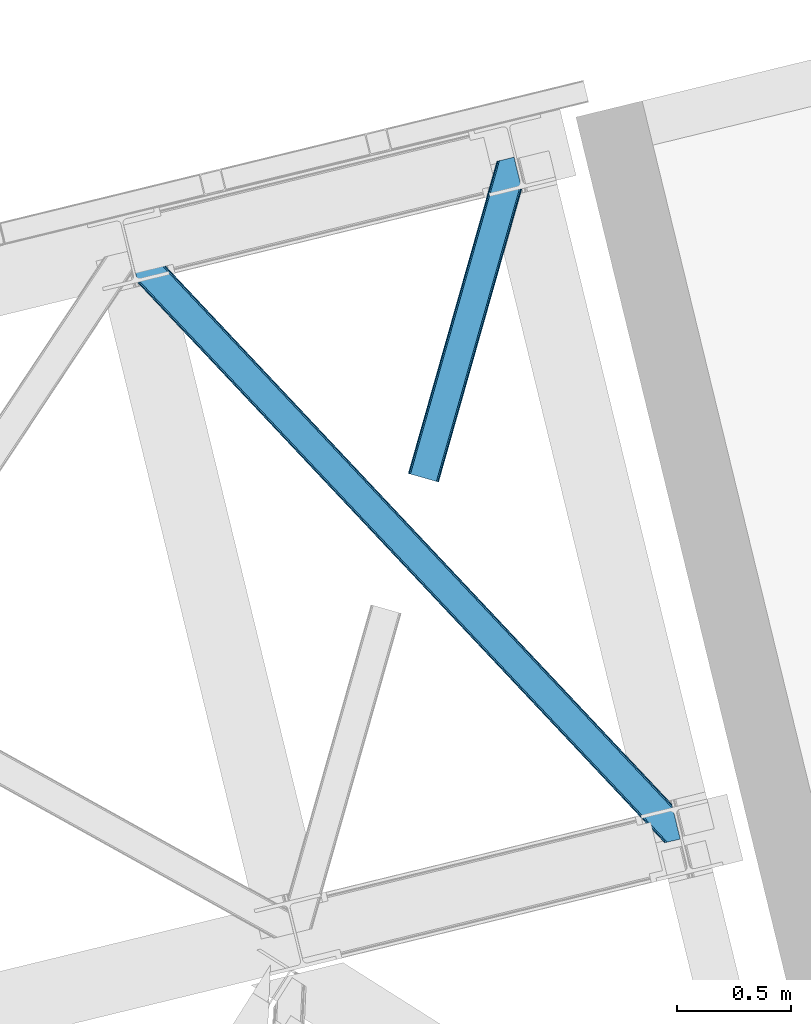
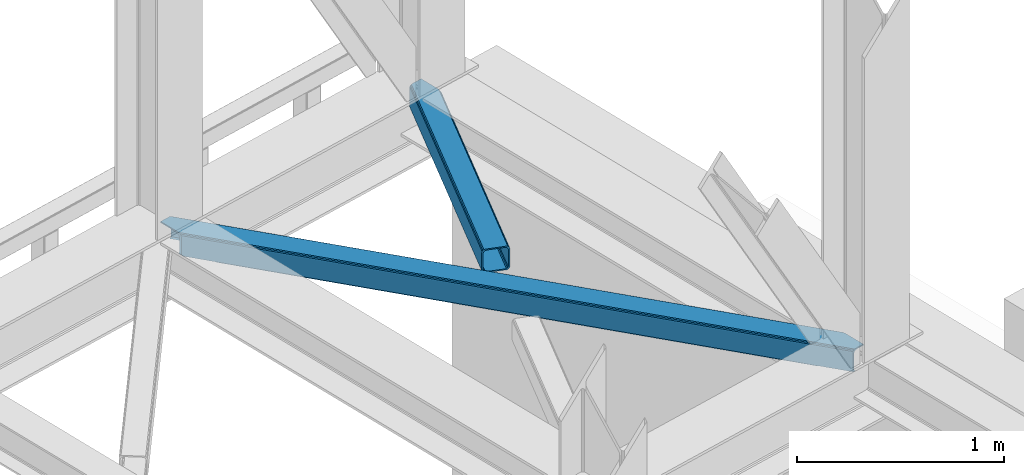
# One storey, part 85 of 92: 2 members.
"""IFC4 building model written with IfcOpenShell, lengths in millimetres."""

from ifc_helpers import new_model, entity, si_unit, converted_unit, derived_unit, direction, frame, origin, place, context, subcontext, project, spatial, triangles, type_object, element, save


model = new_model("IFC4")

# Units and contexts
model_context = context("Model", 3, precision=0.01, world=origin(), true_north=direction((6.12303176911189e-17, 1.0)))
plan_context = context("Plan", 3, precision=0.01, world=origin(), true_north=direction((6.12303176911189e-17, 1.0)))
body_context = subcontext(model_context, "Body", "Model", "MODEL_VIEW")
ifc_project = project(units=[si_unit("LENGTHUNIT", "METRE", prefix="MILLI"), si_unit("AREAUNIT", "SQUARE_METRE"), si_unit("VOLUMEUNIT", "CUBIC_METRE"), converted_unit("PLANEANGLEUNIT", "DEGREE", entity("IfcRatioMeasure", 0.0174532925199433), si_unit("PLANEANGLEUNIT", "RADIAN"), dimensions=[0, 0, 0, 0, 0, 0, 0]), si_unit("MASSUNIT", "GRAM", prefix="KILO"), derived_unit("MASSDENSITYUNIT", [(si_unit("MASSUNIT", "GRAM", prefix="KILO"), 1), (si_unit("LENGTHUNIT", "METRE"), -3)]), derived_unit("MOMENTOFINERTIAUNIT", [(si_unit("LENGTHUNIT", "METRE"), 4)]), si_unit("TIMEUNIT", "SECOND"), si_unit("FREQUENCYUNIT", "HERTZ"), si_unit("THERMODYNAMICTEMPERATUREUNIT", "DEGREE_CELSIUS"), derived_unit("THERMALTRANSMITTANCEUNIT", [(si_unit("MASSUNIT", "GRAM", prefix="KILO"), 1), (si_unit("THERMODYNAMICTEMPERATUREUNIT", "KELVIN"), -1), (si_unit("TIMEUNIT", "SECOND"), -3)]), derived_unit("VOLUMETRICFLOWRATEUNIT", [(si_unit("LENGTHUNIT", "METRE"), 3), (si_unit("TIMEUNIT", "SECOND"), -1)]), derived_unit("MASSFLOWRATEUNIT", [(si_unit("MASSUNIT", "GRAM", prefix="KILO"), 1), (si_unit("TIMEUNIT", "SECOND"), -1)]), derived_unit("ROTATIONALFREQUENCYUNIT", [(si_unit("TIMEUNIT", "SECOND"), -1)]), si_unit("ELECTRICCURRENTUNIT", "AMPERE"), si_unit("ELECTRICVOLTAGEUNIT", "VOLT"), si_unit("POWERUNIT", "WATT"), si_unit("FORCEUNIT", "NEWTON", prefix="KILO"), si_unit("ILLUMINANCEUNIT", "LUX"), si_unit("LUMINOUSFLUXUNIT", "LUMEN"), si_unit("LUMINOUSINTENSITYUNIT", "CANDELA"), derived_unit("USERDEFINED", [(si_unit("MASSUNIT", "GRAM", prefix="KILO"), -1), (si_unit("LENGTHUNIT", "METRE"), -2), (si_unit("TIMEUNIT", "SECOND"), 3), (si_unit("LUMINOUSFLUXUNIT", "LUMEN"), 1)]), derived_unit("LINEARVELOCITYUNIT", [(si_unit("LENGTHUNIT", "METRE"), 1), (si_unit("TIMEUNIT", "SECOND"), -1)]), si_unit("PRESSUREUNIT", "PASCAL"), derived_unit("USERDEFINED", [(si_unit("LENGTHUNIT", "METRE"), -2), (si_unit("MASSUNIT", "GRAM", prefix="KILO"), 1), (si_unit("TIMEUNIT", "SECOND"), -2)]), derived_unit("LINEARFORCEUNIT", [(si_unit("MASSUNIT", "GRAM", prefix="KILO"), 1), (si_unit("LENGTHUNIT", "METRE"), 1), (si_unit("TIMEUNIT", "SECOND"), -2), (si_unit("LENGTHUNIT", "METRE"), -1)]), derived_unit("PLANARFORCEUNIT", [(si_unit("MASSUNIT", "GRAM", prefix="KILO"), 1), (si_unit("LENGTHUNIT", "METRE"), 1), (si_unit("TIMEUNIT", "SECOND"), -2), (si_unit("LENGTHUNIT", "METRE"), -2)])], contexts=[model_context, plan_context])

# Site, building, storey
site_placement = place(None, origin())
site = spatial("IfcSite", under=ifc_project, at=site_placement, CompositionType="ELEMENT")
building_placement = place(site_placement, origin())
building = spatial("IfcBuilding", under=site, at=building_placement, CompositionType="ELEMENT")
storey_placement = place(building_placement, frame((0.0, 0.0, 15900.0)))
storey = spatial("IfcBuildingStorey", under=building, at=storey_placement, Name="05", CompositionType="ELEMENT", Elevation=15900.0)

# Members
member_type_1 = type_object("IfcMemberType", PredefinedType="BRACE")
member_1_placement = place(storey_placement, frame((-2893.85, 17476.17, 3510.02)))
element("IfcMember", 1, at=member_1_placement, inside=storey, type_object=member_type_1, ObjectType="Steel Horizontal Brace", PredefinedType="BRACE", context=body_context, shape_type="Tessellation", body=[
    triangles([(2390.20879182816, 136.983499145506, 140.000756835936), (2386.99318141937, 150.175717163085, 138.668280029298), (56.5227127075195, 2617.59836425781, 140.000756835936), (64.0010353088378, 2619.42150878906, 138.668280029298), (2384.26711235046, 161.358755493166, 134.87548828125), (70.3451248168944, 2620.96792602539, 134.87548828125), (2382.44560289383, 168.831555175781, 129.196765136719), (74.5788780212401, 2622.00042114258, 129.196765136719), (2381.80599803925, 171.455813598634, 122.499499511719), (76.0700660705566, 2622.36318969727, 122.499499511719), (2006.64328708649, 570.234960937501, 17.5000946044929), (2381.80599803925, 171.455813598634, 17.5000946044929), (1617.6124546051, 983.763208007811, 17.5000946044929), (1228.57718925476, 1397.2902923584, 17.5000946044929), (450.510873413086, 2224.3456237793, 17.5000946044929), (76.0700660705566, 2622.36318969727, 17.5000946044929), (839.546284103394, 1810.81853942871, 17.5000946044929), (26.1158477783201, 2496.68248901367, 140.000756835936), (0.0, 2603.82013549805, 140.000756835936), (2370.43223733902, 4.76366271972802, 140.000756835936), (2419.52200984955, 16.7303741455071, 140.000756835936), (2350.88942584991, 0.0, 122.499499511719), (2352.37603569031, 0.362768554688955, 129.196765136719), (34.5188232421874, 2462.2125, 122.499499511719), (33.8790367126462, 2464.83559570312, 129.196765136719), (2356.61443977356, 1.395263671875, 134.87548828125), (32.0576362609863, 2472.30723266601, 134.87548828125), (2362.95402374268, 2.94051818847583, 138.668280029298), (29.3316398620605, 2483.49259643555, 138.668280029298), (1193.06046180725, 1230.72371520996, 17.5000946044929), (1583.89125709534, 815.290933227538, 17.5000946044929), (1974.7174741745, 399.856988525389, 17.5000946044929), (2350.88942584991, 0.0, 17.5000946044929), (802.234317398071, 1646.15765991211, 17.5000946044929), (411.408027648926, 2061.59276733398, 17.5000946044929), (34.5188232421874, 2462.2125, 17.5000946044929), (2364.4315861702, 3.30096130371021, 127.875915527344), (2370.77113380432, 4.84621582031104, 131.668707275392), (2360.19314575195, 2.26730346679688, 122.197192382813), (2378.2538892746, 6.67052307129052, 133.00118408203), (2419.52200984955, 16.7303741455071, 133.00118408203), (2358.70653591156, 1.90569763183521, 115.499926757813), (2358.70653591156, 1.90569763183521, 24.5008300781265), (2360.19314575195, 2.26730346679688, 17.8035644531265), (2352.67877883911, 0.436019897460938, 10.8691040039048), (2353.04928674698, 0.526712036131357, 9.50058288574292), (2364.4315861702, 3.30096130371021, 12.1260040283196), (2368.18651685715, 4.21602172851635, 9.50058288574292), (1982.47063465118, 401.827798461913, 24.5008300781265), (1588.94283828735, 820.135986328125, 24.5008300781265), (1195.4104637146, 1238.44417419434, 24.5008300781265), (31.1576911926268, 2476.00003051758, 115.499926757813), (408.350074768066, 2075.05938720703, 24.5008300781265), (31.1576911926268, 2476.00003051758, 24.5008300781265), (801.882594680786, 1656.75236206055, 24.5008300781265), (25.9705078124998, 2497.28012695313, 131.668707275392), (22.7547157287595, 2510.4723449707, 133.00118408203), (28.6965042114257, 2486.09708862305, 127.875915527344), (30.517904663086, 2478.6231262207, 122.197192382813), (30.3873893737791, 2479.16030273437, 17.8710021972656), (34.5051612854004, 2462.26831054688, 16.5001556396492), (30.22809677124, 2479.8137512207, 16.5001556396492), (0.0, 2603.82013549805, 133.00118408203), (48.7057479858399, 2615.6938293457, 133.00118408203), (2393.56992387772, 123.194805908202, 133.00118408203), (2385.16713008881, 157.66712036133, 115.499926757813), (2385.80673494339, 155.042861938477, 122.197192382813), (66.7619132995605, 2620.09588623047, 122.197192382813), (68.2484504699705, 2620.4563293457, 115.499926757813), (2387.62824440002, 147.570062255858, 127.875915527344), (62.527869415283, 2619.06339111328, 127.875915527344), (2390.35431346893, 136.387023925781, 131.668707275392), (56.1837799072264, 2617.51697387695, 131.668707275392), (1226.23169288635, 1389.57215881348, 24.5008300781265), (1617.96868286133, 973.170831298827, 24.5008300781265), (2009.70560016632, 556.76950378418, 24.5008300781265), (2385.16713008881, 157.66712036133, 24.5008300781265), (834.490197372436, 1805.9723236084, 24.5008300781265), (442.753207397461, 2222.37365112305, 24.5008300781265), (68.2484504699705, 2620.4563293457, 24.5008300781265), (66.7619132995605, 2620.09588623047, 17.8035644531265), (74.2762802124021, 2621.92600708008, 10.8691040039048), (73.9056632995603, 2621.83764038086, 9.50058288574292), (62.527869415283, 2619.06339111328, 12.1260040283196), (58.7728660583493, 2618.14716796875, 9.50058288574292), (2385.9372502327, 154.508010864258, 17.8710021972656), (2386.09654283524, 153.854562377928, 16.5001556396492), (2381.81973266602, 171.398840332033, 16.5001556396492), (41.7939605712891, 2456.42215576172, 10.8039916992202), (36.8073463439941, 2482.3787109375, 9.50058288574292), (34.7757843017575, 2479.63701782226, 12.1260040283196), (43.3136352539063, 2455.68731689453, 9.50058288574292), (170.418958282471, 2340.35482177734, 9.50058288574292), (155.286451721192, 2336.66434936523, 9.50058288574292), (180.780244445801, 2508.2352722168, 9.50058288574292), (187.286533355713, 2481.54155273438, 9.50058288574292), (181.188068389893, 2507.60275268555, 9.25408630371021), (187.878357696533, 2480.72532348633, 9.42384338378906), (181.610426330567, 2506.94930419922, 9.00061340332104), (188.450415802002, 2479.24401855469, 9.11688537597729), (182.028424072265, 2506.29585571289, 8.74597778320458), (189.028287506103, 2477.75573730469, 8.80760192871094), (182.436248016357, 2505.66333618164, 8.50064392089917), (189.60005493164, 2476.27443237305, 8.50064392089917), (2381.54910964966, 154.028970336913, 12.1260040283196), (2374.53078804016, 177.24383239746, 10.8039916992202), (2379.51751127243, 151.288439941407, 9.50058288574292), (2373.01111335754, 177.979833984376, 9.50058288574292), (2233.21012630463, 306.80569152832, 9.50058288574292), (2248.34285087585, 310.495001220705, 9.50058288574292), (2005.67379684448, 569.32222595215, 10.8039916992202), (2002.91328220367, 566.723547363283, 5.12643127441333), (2244.78223972321, 309.626449584961, 5.12643127441333), (449.541455841064, 2223.43405151367, 10.8039916992202), (446.776508331299, 2220.83421020508, 5.12643127441333), (183.700996398926, 2500.47295532226, 5.12643127441333), (442.640714263916, 2216.94375, 1.33247680664135), (186.427283477783, 2489.28991699219, 1.33247680664135), (437.765721130371, 2212.35565795899, 0.0), (189.642784881592, 2476.09769897461, 0.0), (2238.43815021515, 308.080032348633, 1.33247680664135), (2230.95990028381, 306.256887817384, 0.0), (1998.77770614624, 562.833087158204, 1.33247680664135), (1993.89820747375, 558.24383239746, 0.0), (1616.64303703308, 982.850473022459, 10.8039916992202), (1227.60762634277, 1396.37755737305, 10.8039916992202), (838.572215652466, 1809.90464172363, 10.8039916992202), (1613.87794418335, 980.250631713869, 5.12643127441333), (1224.84253349304, 1393.77771606445, 5.12643127441333), (835.811773681641, 1807.30596313476, 5.12643127441333), (1609.74229545593, 976.36017150879, 1.33247680664135), (1220.71153564453, 1389.8884185791, 1.33247680664135), (831.676124954224, 1803.41666564941, 1.33247680664135), (1604.86730232239, 971.772079467773, 0.0), (1215.83203697205, 1385.29916381836, 0.0), (826.796626281738, 1798.82741088867, 0.0), (2008.73153171539, 555.855606079102, 17.8035644531265), (2005.9709444046, 553.256927490234, 12.1260040283196), (439.023202514648, 2218.86223754883, 12.1260040283196), (189.798298645019, 2475.46052856445, 8.41343994140698), (434.887699127197, 2214.97177734375, 8.3320495605476), (193.003916931152, 2462.31016845703, 7.00073547363354), (2001.83544101715, 549.366467285156, 8.3320495605476), (1996.95594234467, 544.777212524416, 7.00073547363354), (2223.14279022217, 304.352352905273, 7.00073547363354), (2230.46741580963, 306.137127685546, 8.81922912597656), (430.008055114746, 2210.38368530274, 7.00073547363354), (441.783789825439, 2221.45975341797, 17.8035644531265), (1610.09852371216, 965.767794799805, 8.3320495605476), (1605.21902503967, 961.178540039062, 7.00073547363354), (1213.4820350647, 1377.57986755371, 7.00073547363354), (1218.36153373718, 1382.16912231445, 8.3320495605476), (821.745045089722, 1793.98119506836, 7.00073547363354), (826.624543762207, 1798.5704498291, 8.3320495605476), (1614.23402709961, 969.658255004884, 12.1260040283196), (1222.49703712463, 1386.05958251953, 12.1260040283196), (830.760192489624, 1802.46091003418, 12.1260040283196), (1616.9946144104, 972.256933593751, 17.8035644531265), (1225.25762443542, 1388.6582611084, 17.8035644531265), (833.520634460449, 1805.05958862305, 17.8035644531265), (219.79792098999, 2352.39129638672, 0.0), (219.79792098999, 2352.39129638672, 7.00073547363354), (173.166464996338, 2341.02454833984, 8.81922912597656), (180.486367034912, 2342.80816040039, 7.00073547363354), (172.669402313232, 2340.90130004883, 0.0), (165.191079711914, 2339.08048095703, 1.33247680664135), (158.846990203857, 2337.5340637207, 5.12643127441333), (424.15317993164, 2073.5827331543, 0.0), (814.97932434082, 1658.14878845215, 0.0), (1205.81011962891, 1242.71600646973, 0.0), (1987.46262645721, 411.846954345703, 0.0), (1596.63640937805, 827.282061767579, 0.0), (2192.71020011902, 296.934201049804, 0.0), (2226.68196372986, 157.568289184572, 0.0), (421.095517730713, 2087.04935302735, 7.00073547363354), (814.627746963501, 1668.74349060059, 7.00073547363354), (1208.15561599731, 1250.43414001465, 7.00073547363354), (1995.22029247284, 413.820089721681, 7.00073547363354), (2192.71020011902, 296.934201049804, 7.00073547363354), (2223.3208316803, 171.356982421876, 7.00073547363354), (1601.68799057007, 832.127114868163, 7.00073547363354), (1975.68703708649, 400.768560791017, 10.8039916992202), (412.377445220947, 2062.50433959961, 10.8039916992202), (415.142683410645, 2065.1041809082, 5.12643127441333), (2235.13660755157, 126.065560913084, 9.25408630371021), (2234.7142496109, 126.717846679687, 9.00061340332104), (2235.54457683563, 125.433041381835, 9.50058288574292), (2234.29632453918, 127.372457885744, 8.74597778320458), (2233.88835525513, 128.004977416993, 8.50064392089917), (1978.45205726624, 403.368402099608, 5.12643127441333), (2232.62367954254, 133.193032836913, 5.12643127441333), (2229.89761047363, 144.376071166993, 1.33247680664135), (1982.58312778473, 407.257699584959, 1.33247680664135), (419.278186798096, 2068.99464111328, 1.33247680664135), (1591.75691070557, 822.692807006835, 1.33247680664135), (1200.93062095642, 1238.12675170898, 1.33247680664135), (810.104331207275, 1653.56069641113, 1.33247680664135), (1587.62126197815, 818.802346801756, 5.12643127441333), (1196.79511756897, 1234.2362915039, 5.12643127441333), (805.968827819824, 1649.67023620605, 5.12643127441333), (1584.86082000732, 816.203668212889, 10.8039916992202), (1194.03453025818, 1231.63761291504, 10.8039916992202), (803.203734970093, 1647.07039489746, 10.8039916992202), (1990.34079380035, 409.230834960938, 8.3320495605476), (2227.21637878418, 155.690496826173, 8.8831787109375), (2226.72454833984, 157.393881225587, 8.50064392089917), (1986.20521774292, 405.340374755859, 12.1260040283196), (2229.03814258575, 152.124435424805, 9.50058288574292), (2228.43301963806, 153.310409545898, 9.2947814941399), (2227.82150173187, 154.503359985352, 9.08898010254052), (2226.52637729645, 158.206622314454, 8.41343994140698), (416.220524597168, 2082.46126098633, 8.3320495605476), (412.084730529785, 2078.5731262207, 12.1260040283196), (409.319783020019, 2075.97328491211, 17.8035644531265), (1983.44470310211, 402.741696166991, 17.8035644531265), (1589.91240119934, 821.048721313477, 17.8035644531265), (1196.38002662659, 1239.35690917969, 17.8035644531265), (802.852157592773, 1657.6650970459, 17.8035644531265), (1592.67284317017, 823.647399902344, 12.1260040283196), (1199.14497413635, 1241.95675048828, 12.1260040283196), (805.612599563598, 1660.26377563476, 12.1260040283196), (1596.80849189758, 827.537860107423, 8.3320495605476), (1203.28062286377, 1245.84604797363, 8.3320495605476), (809.748248291015, 1664.15423583984, 8.3320495605476)], [[1, 2, 3], [4, 3, 2], [2, 5, 4], [6, 4, 5], [5, 7, 6], [8, 6, 7], [7, 9, 8], [10, 8, 9], [11, 9, 12], [9, 11, 13], [9, 14, 10], [14, 9, 13], [15, 16, 10], [17, 10, 14], [10, 17, 15], [3, 18, 1], [3, 19, 18], [20, 1, 18], [21, 1, 20], [22, 23, 24], [25, 24, 23], [23, 26, 25], [27, 25, 26], [26, 28, 27], [29, 27, 28], [28, 20, 29], [18, 29, 20], [30, 22, 24], [22, 31, 32], [30, 31, 22], [32, 33, 22], [34, 24, 35], [24, 34, 30], [36, 35, 24], [37, 38, 28], [26, 37, 28], [37, 26, 23], [39, 37, 23], [39, 23, 22], [38, 20, 28], [21, 40, 41], [21, 20, 40], [38, 40, 20], [39, 22, 42], [43, 33, 44], [22, 43, 42], [33, 45, 44], [22, 33, 43], [46, 47, 45], [47, 44, 45], [48, 47, 46], [49, 42, 43], [42, 49, 50], [42, 51, 52], [51, 42, 50], [53, 54, 52], [55, 52, 51], [52, 55, 53], [40, 38, 56], [56, 57, 40], [38, 37, 58], [58, 56, 38], [37, 39, 59], [59, 58, 37], [39, 42, 52], [52, 59, 39], [60, 61, 62], [24, 36, 54], [36, 60, 54], [54, 52, 24], [36, 61, 60], [59, 24, 52], [25, 24, 59], [27, 59, 58], [59, 27, 25], [58, 29, 27], [56, 29, 58], [56, 57, 18], [56, 18, 29], [57, 19, 18], [57, 63, 19], [57, 64, 65], [64, 57, 63], [65, 40, 57], [41, 40, 65], [66, 67, 68], [68, 69, 66], [67, 70, 71], [71, 68, 67], [70, 72, 73], [73, 71, 70], [72, 65, 64], [64, 73, 72], [74, 66, 69], [66, 75, 76], [74, 75, 66], [76, 77, 66], [78, 69, 79], [69, 78, 74], [80, 79, 69], [71, 73, 4], [6, 71, 4], [71, 6, 8], [68, 71, 8], [68, 8, 10], [73, 3, 4], [19, 64, 63], [19, 3, 64], [73, 64, 3], [68, 10, 69], [80, 16, 81], [10, 80, 69], [16, 82, 81], [10, 16, 80], [83, 84, 82], [84, 81, 82], [85, 84, 83], [70, 5, 2], [65, 72, 1], [72, 70, 2], [86, 87, 88], [41, 65, 21], [1, 21, 65], [72, 2, 1], [86, 12, 77], [9, 66, 77], [77, 12, 9], [86, 88, 12], [9, 67, 66], [67, 5, 70], [5, 67, 7], [9, 7, 67], [89, 90, 91], [89, 92, 90], [91, 61, 89], [62, 61, 91], [92, 90, 93], [93, 94, 92], [85, 83, 95], [95, 96, 85], [97, 98, 96], [99, 100, 98], [101, 102, 100], [103, 104, 102], [102, 101, 103], [100, 99, 101], [98, 97, 99], [96, 95, 97], [88, 105, 106], [105, 88, 87], [107, 106, 105], [107, 108, 106], [109, 110, 108], [108, 107, 109], [12, 88, 106], [111, 106, 110], [110, 112, 111], [110, 113, 112], [106, 108, 110], [114, 101, 99], [101, 114, 103], [114, 97, 95], [97, 114, 99], [95, 82, 114], [95, 83, 82], [114, 115, 116], [116, 103, 114], [114, 82, 16], [16, 15, 114], [115, 117, 118], [118, 116, 115], [117, 119, 120], [120, 118, 117], [121, 122, 123], [124, 123, 122], [113, 121, 112], [123, 112, 121], [12, 106, 11], [111, 11, 106], [11, 111, 13], [125, 13, 111], [13, 125, 14], [126, 14, 125], [14, 126, 127], [127, 17, 14], [17, 127, 15], [114, 15, 127], [111, 112, 128], [128, 125, 111], [125, 128, 126], [129, 126, 128], [126, 129, 127], [130, 127, 129], [127, 130, 115], [115, 114, 127], [112, 123, 131], [131, 128, 112], [128, 131, 132], [132, 129, 128], [129, 132, 130], [133, 130, 132], [130, 133, 115], [117, 115, 133], [123, 124, 134], [134, 131, 123], [131, 134, 135], [135, 132, 131], [132, 135, 136], [136, 133, 132], [133, 136, 119], [119, 117, 133], [137, 138, 105], [105, 87, 137], [137, 86, 77], [139, 104, 140], [102, 139, 100], [102, 104, 139], [98, 100, 139], [96, 139, 84], [84, 85, 96], [96, 98, 139], [141, 140, 142], [143, 144, 145], [138, 143, 146], [146, 109, 138], [107, 105, 109], [138, 109, 105], [145, 146, 143], [142, 147, 141], [140, 141, 139], [139, 148, 81], [81, 84, 139], [148, 79, 80], [80, 81, 148], [77, 76, 137], [87, 86, 137], [144, 143, 149], [149, 150, 144], [150, 149, 151], [152, 151, 149], [151, 152, 153], [154, 153, 152], [153, 154, 147], [141, 147, 154], [143, 138, 155], [155, 149, 143], [149, 155, 156], [156, 152, 149], [152, 156, 157], [157, 154, 152], [154, 157, 141], [139, 141, 157], [138, 137, 155], [158, 155, 137], [155, 158, 156], [159, 156, 158], [156, 159, 160], [160, 157, 156], [157, 160, 148], [148, 139, 157], [137, 76, 75], [75, 158, 137], [158, 75, 74], [74, 159, 158], [159, 74, 160], [78, 160, 74], [160, 78, 148], [79, 148, 78], [104, 120, 140], [118, 104, 116], [104, 118, 120], [104, 103, 116], [140, 120, 142], [142, 161, 162], [161, 142, 120], [163, 164, 165], [93, 165, 166], [166, 167, 93], [161, 164, 162], [164, 161, 165], [167, 94, 93], [165, 93, 163], [168, 165, 161], [119, 168, 161], [119, 161, 120], [136, 168, 119], [169, 168, 136], [135, 169, 136], [169, 135, 170], [124, 171, 172], [170, 134, 172], [134, 170, 135], [134, 124, 172], [124, 173, 171], [171, 173, 174], [122, 173, 124], [153, 147, 175], [175, 176, 153], [176, 151, 153], [151, 176, 177], [147, 164, 175], [162, 147, 142], [147, 162, 164], [145, 144, 178], [178, 179, 145], [179, 178, 180], [144, 181, 178], [150, 177, 181], [177, 150, 151], [144, 150, 181], [146, 145, 122], [109, 122, 121], [121, 113, 109], [173, 145, 179], [145, 173, 122], [113, 110, 109], [122, 109, 146], [182, 45, 33], [36, 61, 89], [183, 89, 94], [94, 184, 183], [94, 167, 184], [89, 92, 94], [185, 182, 186], [185, 187, 182], [182, 188, 186], [182, 189, 188], [187, 45, 182], [187, 46, 45], [182, 190, 191], [191, 189, 182], [192, 191, 190], [190, 193, 192], [174, 192, 193], [193, 171, 174], [168, 194, 165], [166, 165, 194], [194, 184, 166], [167, 166, 184], [183, 35, 89], [36, 89, 35], [33, 32, 182], [171, 193, 195], [195, 172, 171], [172, 195, 196], [196, 170, 172], [170, 196, 197], [197, 169, 170], [169, 197, 194], [194, 168, 169], [193, 190, 195], [198, 195, 190], [195, 198, 196], [199, 196, 198], [196, 199, 197], [200, 197, 199], [197, 200, 194], [184, 194, 200], [190, 182, 201], [201, 198, 190], [198, 201, 202], [202, 199, 198], [199, 202, 200], [203, 200, 202], [200, 203, 183], [183, 184, 200], [182, 32, 201], [31, 201, 32], [201, 31, 30], [30, 202, 201], [202, 30, 34], [34, 203, 202], [203, 34, 35], [35, 183, 203], [204, 205, 206], [207, 208, 209], [209, 204, 207], [209, 210, 204], [205, 204, 210], [206, 211, 204], [47, 48, 208], [208, 207, 47], [204, 211, 180], [212, 175, 164], [213, 212, 163], [163, 93, 213], [214, 213, 91], [91, 62, 214], [214, 60, 54], [54, 53, 214], [62, 60, 214], [213, 93, 91], [90, 91, 93], [164, 163, 212], [180, 178, 204], [44, 47, 207], [207, 215, 44], [43, 44, 215], [215, 49, 43], [49, 215, 50], [216, 50, 215], [50, 216, 51], [217, 51, 216], [51, 217, 218], [218, 55, 51], [55, 218, 53], [214, 53, 218], [215, 207, 219], [219, 216, 215], [216, 219, 220], [220, 217, 216], [217, 220, 218], [221, 218, 220], [218, 221, 214], [213, 214, 221], [207, 204, 219], [222, 219, 204], [219, 222, 220], [223, 220, 222], [220, 223, 224], [224, 221, 220], [221, 224, 212], [212, 213, 221], [204, 178, 222], [181, 222, 178], [222, 181, 223], [177, 223, 181], [223, 177, 224], [176, 224, 177], [224, 176, 212], [175, 212, 176], [174, 211, 206], [179, 180, 173], [180, 211, 174], [174, 173, 180], [192, 174, 206], [206, 189, 191], [191, 192, 206], [189, 206, 205], [188, 205, 210], [186, 210, 209], [185, 209, 208], [208, 187, 185], [209, 185, 186], [210, 186, 188], [205, 188, 189], [187, 208, 48], [48, 46, 187]]),
])
member_type_2 = type_object("IfcMemberType", PredefinedType="BRACE")
member_2_placement = place(storey_placement, frame((-1671.07, 19062.47, 3510.02)))
element("IfcMember", 2, at=member_2_placement, inside=storey, type_object=member_type_2, ObjectType="Steel Horizontal Brace", PredefinedType="BRACE", context=body_context, shape_type="Tessellation", body=[
    triangles([(500.301584243774, 1287.51443481445, 17.5000946044929), (500.301584243774, 1287.51443481445, 122.499499511719), (134.676372528076, 0.0, 17.5000946044929), (134.676372528076, 0.0, 122.499499511719), (495.114400863647, 1308.79453125, 138.668280029298), (491.898754119873, 1321.98674926758, 140.000756835936), (117.842952346802, 4.77994079589553, 140.000756835936), (124.282530212402, 2.94981994628688, 138.668280029298), (497.840469932556, 1297.61149291992, 134.87548828125), (129.74440612793, 1.39991455078052, 134.87548828125), (499.662015724182, 1290.13985595703, 129.196765136719), (133.395636749268, 0.363931274412607, 129.196765136719), (16.8379257202148, 33.4642364501924, 140.000756835936), (409.260048294067, 1415.34616699219, 140.000756835936), (465.782761001587, 1429.12439575195, 140.000756835936), (391.19923210144, 1410.94411010742, 129.196765136719), (389.71269493103, 1410.58134155273, 122.499499511719), (1.28073577880855, 37.880245971679, 129.196765136719), (0.0, 38.2441772460916, 122.499499511719), (395.437636184692, 1411.97660522461, 134.87548828125), (4.93196640014662, 36.844262695311, 134.87548828125), (401.777220153809, 1413.52302246094, 138.668280029298), (10.393842315674, 35.2931945800774, 138.668280029298), (389.71269493103, 1410.58134155273, 17.5000946044929), (0.0, 38.2441772460916, 17.5000946044929), (1.28073577880855, 37.880245971679, 10.8039916992202), (391.19923210144, 1410.94411010742, 10.8039916992202), (350.625400543213, 1255.50010986328, 5.50082702636792), (4.93196640014662, 36.844262695311, 5.12643127441333), (350.610866546631, 1254.51877441406, 5.25316772460792), (395.030974960327, 1411.87893676758, 5.50082702636792), (350.591681671143, 1253.51883544922, 5.00085754394604), (10.393842315674, 35.2931945800774, 1.33247680664135), (350.577002334595, 1252.51657104492, 4.74854736328052), (350.562613677979, 1251.53756103515, 4.50088806152417), (352.972204971313, 1241.65211791992, 1.33247680664135), (356.187851715088, 1228.45989990234, 0.0), (16.8379257202148, 33.4642364501924, 0.0), (386.342987823486, 1104.751171875, 0.0), (117.842952346802, 4.77994079589553, 0.0), (433.47165184021, 1116.23884277344, 0.0), (447.69621963501, 1119.70607299804, 5.50082702636792), (440.949974441528, 1118.06198730469, 1.33247680664135), (387.314440155029, 1104.98836669922, 5.50082702636792), (386.342987823486, 1104.751171875, 4.50088806152417), (498.721520805359, 1286.82843017578, 10.8039916992202), (133.395636749268, 0.363931274412607, 10.8039916992202), (129.74440612793, 1.39991455078052, 5.12643127441333), (124.282530212402, 2.94981994628688, 1.33247680664135), (494.138297653198, 1283.24260253906, 5.50082702636792), (499.951314926147, 1288.95155639648, 12.5003997802742), (458.982304000855, 1427.46635742187, 5.50082702636792), (494.653818511963, 1310.68511352539, 12.5003997802742), (489.445488166809, 1314.45465087891, 8.3320495605476), (485.489479637146, 1325.04702758789, 7.00073547363354), (460.437302398682, 1427.8221496582, 7.00073547363354), (23.5703636169435, 31.5515624999971, 7.00073547363354), (417.077158355713, 1417.2507019043, 7.00073547363354), (111.110514450073, 6.69261474609084, 7.00073547363354), (496.300883674622, 1303.92738647461, 17.8035644531265), (123.011968231201, 3.31258850097583, 12.1260040283196), (126.663198852539, 2.27660522460792, 17.8035644531265), (496.940452194214, 1301.30429077148, 24.5008300781265), (127.943934631348, 1.91151123046802, 24.5008300781265), (117.550092315674, 4.86249389648219, 8.3320495605476), (496.940452194214, 1301.30429077148, 115.499926757813), (127.943934631348, 1.91151123046802, 115.499926757813), (496.300883674622, 1303.92738647461, 122.197192382813), (494.479337882996, 1311.3990234375, 127.875915527344), (491.75334148407, 1322.58206176758, 131.668707275392), (488.537622070313, 1335.77427978515, 133.00118408203), (465.782761001587, 1429.12439575195, 133.00118408203), (126.663198852539, 2.27660522460792, 122.197192382813), (123.011968231201, 3.31258850097583, 127.875915527344), (117.550092315674, 4.86249389648219, 131.668707275392), (111.110514450073, 6.69261474609084, 133.00118408203), (23.5703636169435, 31.5515624999971, 133.00118408203), (417.077158355713, 1417.2507019043, 133.00118408203), (11.6645496368408, 34.9315887451157, 127.875915527344), (17.1264255523681, 33.3805206298821, 131.668707275392), (6.73694343566899, 36.3326660156235, 115.499926757813), (8.01767921447754, 35.9687347412109, 122.197192382813), (11.6645496368408, 34.9315887451157, 12.1260040283196), (17.1264255523681, 33.3805206298821, 8.3320495605476), (6.73694343566899, 36.3326660156235, 24.5008300781265), (8.01767921447754, 35.9687347412109, 17.8035644531265), (409.598835754394, 1415.4298828125, 131.668707275392), (403.254746246338, 1413.88346557617, 127.875915527344), (399.020847702026, 1412.85097045898, 122.197192382813), (397.529804992676, 1412.48587646484, 115.499926757813), (409.598835754394, 1415.4298828125, 8.3320495605476), (399.020847702026, 1412.85097045898, 17.8035644531265), (403.254746246338, 1413.88346557617, 12.1260040283196), (397.529804992676, 1412.48587646484, 24.5008300781265)], [[1, 2, 3], [4, 3, 2], [5, 6, 7], [7, 8, 5], [9, 5, 8], [8, 10, 9], [11, 9, 10], [10, 12, 11], [2, 11, 12], [12, 4, 2], [13, 6, 14], [13, 7, 6], [6, 15, 14], [16, 17, 18], [19, 18, 17], [20, 16, 21], [18, 21, 16], [22, 20, 23], [21, 23, 20], [14, 22, 13], [23, 13, 22], [17, 24, 19], [25, 19, 24], [26, 27, 28], [28, 29, 26], [28, 30, 29], [27, 31, 28], [32, 33, 29], [32, 34, 33], [35, 33, 34], [35, 36, 33], [36, 37, 33], [38, 33, 37], [24, 27, 26], [26, 25, 24], [39, 38, 37], [40, 39, 41], [39, 40, 38], [41, 42, 43], [41, 39, 44], [41, 44, 42], [44, 39, 45], [30, 28, 44], [34, 32, 44], [35, 34, 45], [37, 35, 45], [37, 36, 35], [45, 39, 37], [46, 1, 3], [3, 47, 46], [48, 49, 43], [47, 48, 42], [50, 46, 42], [47, 42, 46], [43, 42, 48], [41, 43, 49], [49, 40, 41], [46, 51, 1], [42, 28, 50], [42, 44, 28], [31, 50, 28], [52, 50, 31], [53, 50, 54], [51, 46, 53], [53, 46, 50], [55, 50, 52], [50, 55, 54], [52, 56, 55], [57, 55, 58], [57, 59, 55], [55, 56, 58], [60, 53, 61], [61, 62, 60], [63, 60, 62], [62, 64, 63], [54, 55, 59], [59, 65, 54], [53, 54, 65], [65, 61, 53], [66, 63, 67], [64, 67, 63], [60, 51, 53], [2, 1, 63], [1, 60, 63], [63, 66, 2], [1, 51, 60], [68, 2, 66], [11, 2, 68], [9, 68, 69], [68, 9, 11], [69, 5, 9], [70, 5, 69], [70, 71, 6], [70, 6, 5], [71, 15, 6], [71, 72, 15], [68, 66, 73], [67, 73, 66], [69, 68, 74], [73, 74, 68], [70, 69, 75], [74, 75, 69], [71, 70, 76], [75, 76, 70], [77, 71, 76], [71, 77, 78], [72, 71, 78], [12, 74, 73], [67, 3, 4], [12, 73, 4], [12, 10, 74], [73, 67, 4], [74, 10, 8], [76, 7, 13], [7, 75, 8], [75, 7, 76], [75, 74, 8], [47, 61, 48], [64, 3, 67], [3, 62, 47], [62, 3, 64], [47, 62, 61], [40, 59, 38], [49, 48, 61], [61, 65, 49], [65, 59, 40], [40, 49, 65], [79, 23, 21], [13, 77, 76], [13, 80, 77], [80, 13, 23], [79, 80, 23], [81, 19, 25], [18, 82, 79], [21, 18, 79], [82, 18, 19], [81, 82, 19], [33, 83, 29], [38, 59, 57], [57, 84, 38], [84, 83, 33], [33, 38, 84], [26, 29, 83], [25, 85, 81], [86, 25, 26], [25, 86, 85], [86, 26, 83], [22, 14, 87], [15, 78, 14], [78, 15, 72], [78, 87, 14], [88, 22, 87], [88, 20, 22], [16, 88, 89], [88, 16, 20], [17, 89, 90], [89, 17, 16], [58, 31, 91], [92, 93, 27], [93, 91, 31], [58, 52, 31], [52, 58, 56], [94, 92, 24], [27, 24, 92], [17, 94, 24], [94, 17, 90], [93, 31, 27], [87, 78, 77], [77, 80, 87], [88, 87, 80], [80, 79, 88], [89, 88, 79], [79, 82, 89], [90, 89, 82], [82, 81, 90], [94, 90, 85], [81, 85, 90], [92, 94, 86], [85, 86, 94], [93, 92, 83], [86, 83, 92], [91, 93, 84], [83, 84, 93], [58, 91, 57], [84, 57, 91]]),
])

save(model, "model.ifc")
